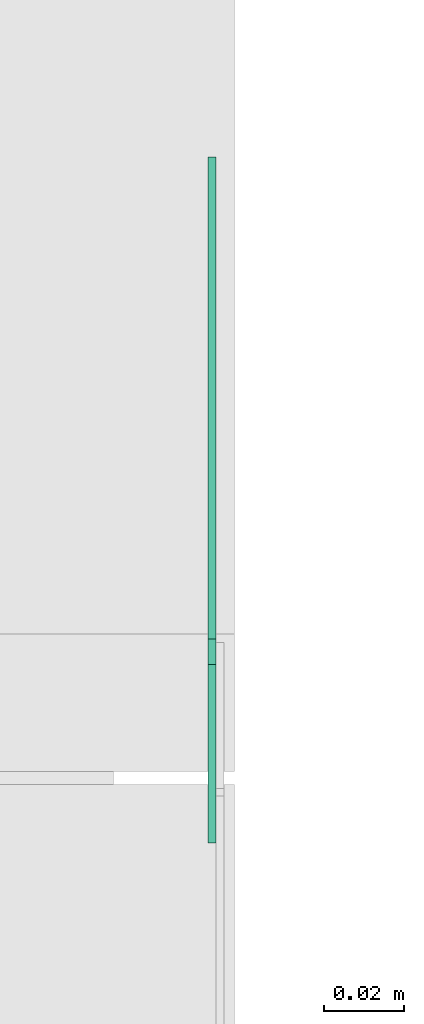
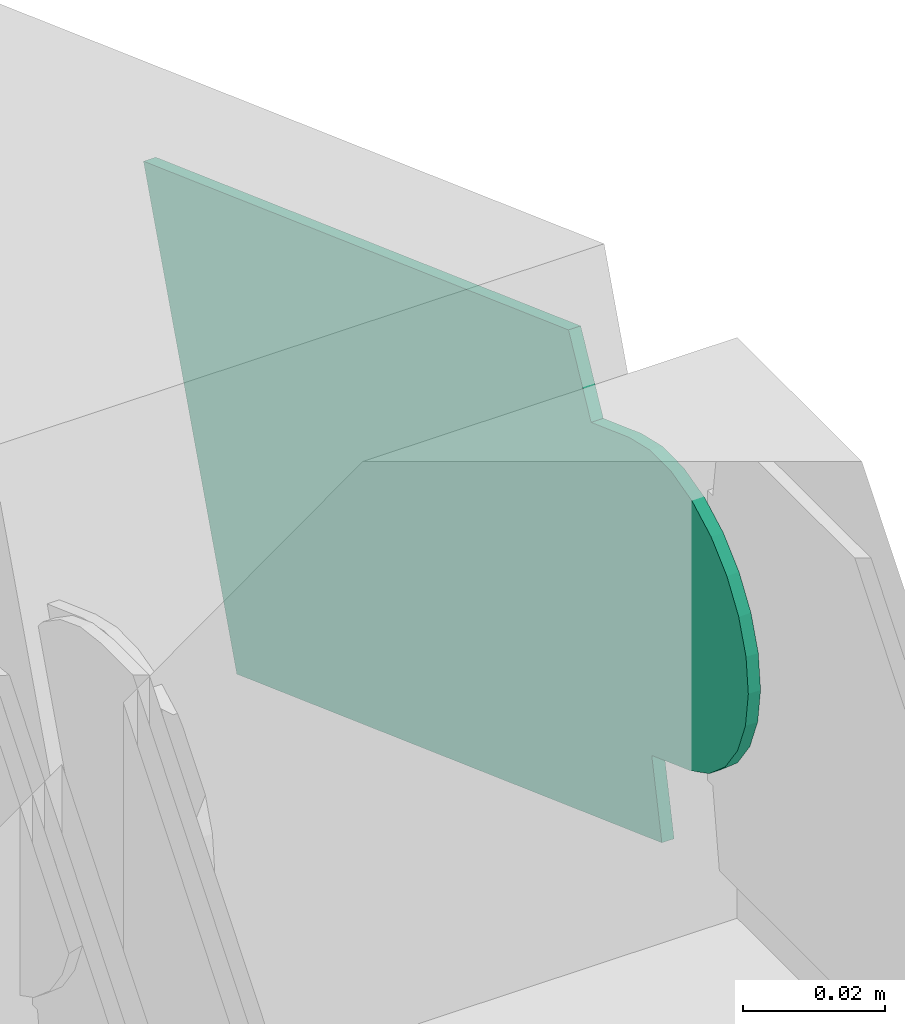
# One storey, part 28 of 32: 1 flow fitting.
"""IFC2X3 building model written with IfcOpenShell, lengths in millimetres."""

from ifc_helpers import new_model, entity, si_unit, converted_unit, derived_unit, direction, frame, frame_2d, origin, place, context, subcontext, project, spatial, polyline, circle_curve, parameter, trimmed, segment, composite_curve, outline, extrude, source, transform, mapped, material, type_object, type_shapes, element, save


model = new_model("IFC2X3")

# Units and contexts
model_context = context("Model", 3, precision=0.01, world=origin(), true_north=direction((6.12303176911189e-17, 1.0)))
body_context = subcontext(model_context, "Body", "Model", "MODEL_VIEW")
ifc_project = project(units=[si_unit("LENGTHUNIT", "METRE", prefix="MILLI"), si_unit("AREAUNIT", "SQUARE_METRE"), si_unit("VOLUMEUNIT", "CUBIC_METRE"), converted_unit("PLANEANGLEUNIT", "DEGREE", entity("IfcRatioMeasure", 0.0174532925199433), si_unit("PLANEANGLEUNIT", "RADIAN"), dimensions=[0, 0, 0, 0, 0, 0, 0]), si_unit("MASSUNIT", "GRAM", prefix="KILO"), derived_unit("MASSDENSITYUNIT", [(si_unit("MASSUNIT", "GRAM", prefix="KILO"), 1), (si_unit("LENGTHUNIT", "METRE"), -3)]), derived_unit("MOMENTOFINERTIAUNIT", [(si_unit("LENGTHUNIT", "METRE"), 4)]), si_unit("TIMEUNIT", "SECOND"), si_unit("FREQUENCYUNIT", "HERTZ"), si_unit("THERMODYNAMICTEMPERATUREUNIT", "DEGREE_CELSIUS"), derived_unit("THERMALTRANSMITTANCEUNIT", [(si_unit("MASSUNIT", "GRAM", prefix="KILO"), 1), (si_unit("THERMODYNAMICTEMPERATUREUNIT", "KELVIN"), -1), (si_unit("TIMEUNIT", "SECOND"), -3)]), derived_unit("VOLUMETRICFLOWRATEUNIT", [(si_unit("LENGTHUNIT", "METRE"), 3), (si_unit("TIMEUNIT", "SECOND"), -1)]), derived_unit("MASSFLOWRATEUNIT", [(si_unit("MASSUNIT", "GRAM", prefix="KILO"), 1), (si_unit("TIMEUNIT", "SECOND"), -1)]), derived_unit("ROTATIONALFREQUENCYUNIT", [(si_unit("TIMEUNIT", "SECOND"), -1)]), si_unit("ELECTRICCURRENTUNIT", "AMPERE"), si_unit("ELECTRICVOLTAGEUNIT", "VOLT"), si_unit("POWERUNIT", "WATT"), si_unit("FORCEUNIT", "NEWTON", prefix="KILO"), si_unit("ILLUMINANCEUNIT", "LUX"), si_unit("LUMINOUSFLUXUNIT", "LUMEN"), si_unit("LUMINOUSINTENSITYUNIT", "CANDELA"), derived_unit("USERDEFINED", [(si_unit("MASSUNIT", "GRAM", prefix="KILO"), -1), (si_unit("LENGTHUNIT", "METRE"), -2), (si_unit("TIMEUNIT", "SECOND"), 3), (si_unit("LUMINOUSFLUXUNIT", "LUMEN"), 1)]), derived_unit("LINEARVELOCITYUNIT", [(si_unit("LENGTHUNIT", "METRE"), 1), (si_unit("TIMEUNIT", "SECOND"), -1)]), si_unit("PRESSUREUNIT", "PASCAL"), derived_unit("USERDEFINED", [(si_unit("LENGTHUNIT", "METRE"), -2), (si_unit("MASSUNIT", "GRAM", prefix="KILO"), 1), (si_unit("TIMEUNIT", "SECOND"), -2)]), derived_unit("LINEARFORCEUNIT", [(si_unit("MASSUNIT", "GRAM", prefix="KILO"), 1), (si_unit("LENGTHUNIT", "METRE"), 1), (si_unit("TIMEUNIT", "SECOND"), -2), (si_unit("LENGTHUNIT", "METRE"), -1)]), derived_unit("PLANARFORCEUNIT", [(si_unit("MASSUNIT", "GRAM", prefix="KILO"), 1), (si_unit("LENGTHUNIT", "METRE"), 1), (si_unit("TIMEUNIT", "SECOND"), -2), (si_unit("LENGTHUNIT", "METRE"), -2)])], contexts=[model_context])

# Site, building, storey
site_placement = place(None, origin())
site = spatial("IfcSite", under=ifc_project, at=site_placement, CompositionType="ELEMENT")
building_placement = place(site_placement, origin())
building = spatial("IfcBuilding", under=site, at=building_placement, CompositionType="ELEMENT")
storey_placement = place(building_placement, frame((0.0, 0.0, 8100.0)))
storey = spatial("IfcBuildingStorey", under=building, at=storey_placement, CompositionType="ELEMENT", Elevation=8100.0)

# Flow fitting
ifc_material = material(Name="G")
cable_carrier_fitting_type = type_object("IfcCableCarrierFittingType", PredefinedType="NOTDEFINED", material=ifc_material)
shared_shape = source(origin(), body_context, "Body", "SweptSolid", [
    extrude(outline(composite_curve([segment(trimmed(circle_curve(frame_2d((-41.47, 0.0), x_axis=(1.0, 0.0)), 25.0), [parameter(90.0000000000007)], [parameter(270.0)], True, "PARAMETER"), True, "CONTINUOUS"), segment(polyline([(-41.47, -25.0), (-29.97, -25.0)]), True, "CONTINUOUS"), segment(polyline([(-29.97, -25.0), (-28.1, -38.5)]), True, "CONTINUOUS"), segment(polyline([(-28.1, -38.5), (99.53, -38.5)]), True, "CONTINUOUS"), segment(polyline([(99.53, -38.5), (99.53, 38.5)]), True, "CONTINUOUS"), segment(polyline([(99.53, 38.5), (-28.1, 38.5)]), True, "CONTINUOUS"), segment(polyline([(-28.1, 38.5), (-29.97, 25.0)]), True, "CONTINUOUS"), segment(polyline([(-29.97, 25.0), (-41.47, 25.0)]), True, "CONTINUOUS")], self_intersect=False)), frame((41.47, 0.0, 0.0)), (0.0, 0.0, 1.0), 2.0),
])
type_shapes(cable_carrier_fitting_type, [shared_shape])
flow_fitting_placement = place(storey_placement, frame((60813.57, 13195.13, 2900.1), z_axis=(1.0, 0.0, 0.0), x_axis=(0.0, 0.939662088474052, -0.342104018515689)))
element("IfcFlowFitting", 1, at=flow_fitting_placement, inside=storey, type_object=cable_carrier_fitting_type, material=ifc_material, context=body_context, shape_type="MappedRepresentation", body=[
    mapped(shared_shape, transform((0.0, 0.0, 0.0), scale=1.0)),
])

save(model, "model.ifc")
